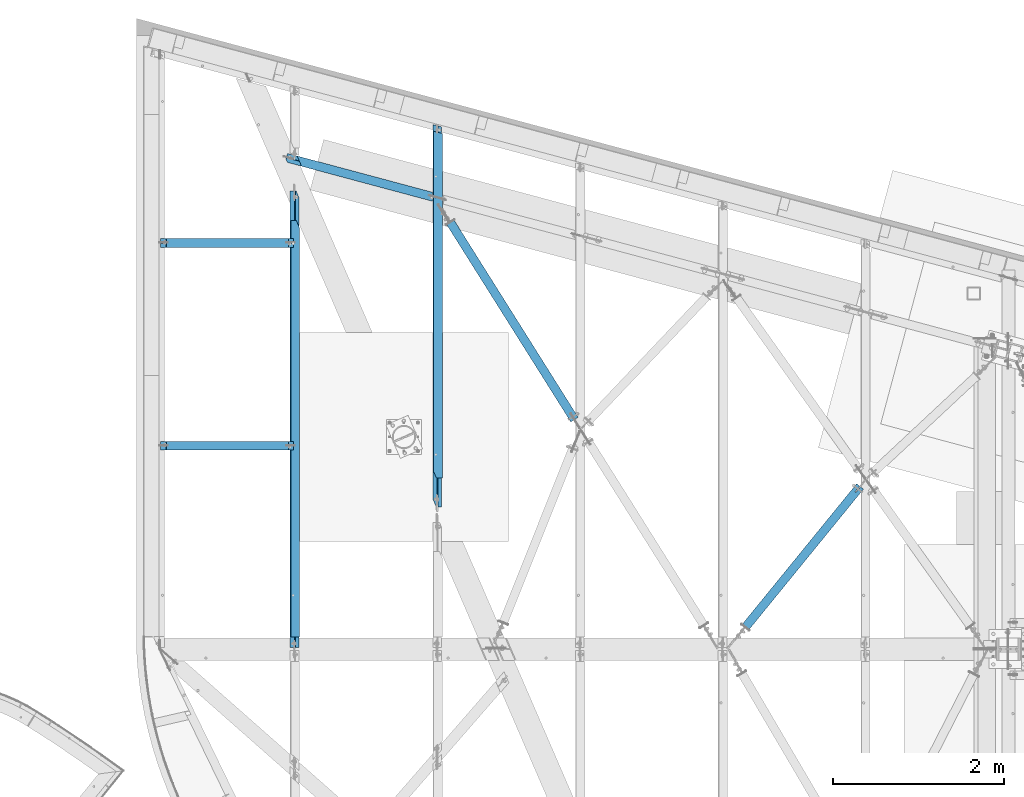
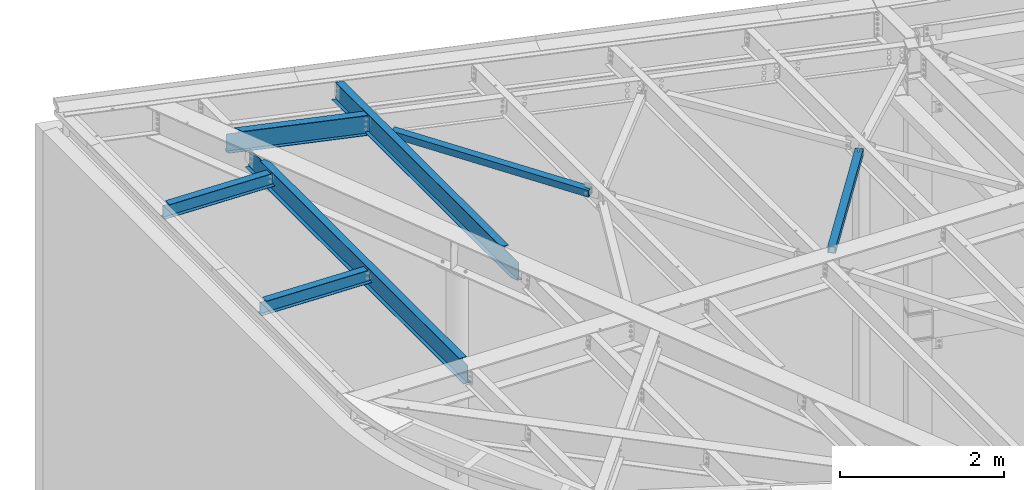
# One storey, part 1156 of 1763: 7 beams, 7 elements without a shape of their own.
"""IFC2X3 building model written with IfcOpenShell, lengths in millimetres."""

from ifc_helpers import new_model, si_unit, frame, origin_with_axes, place, context, subcontext, project, spatial, faceted_brep, material, type_object, element, aggregate, save


model = new_model("IFC2X3")

# Units and contexts
model_context = context("Model", 3, precision=1e-05, world=origin_with_axes())
body_context = subcontext(model_context, "Body", "Model", "MODEL_VIEW")
ifc_project = project(units=[si_unit("LENGTHUNIT", "METRE", prefix="MILLI"), si_unit("AREAUNIT", "SQUARE_METRE"), si_unit("VOLUMEUNIT", "CUBIC_METRE"), si_unit("MASSUNIT", "GRAM", prefix="KILO"), si_unit("TIMEUNIT", "SECOND"), si_unit("PLANEANGLEUNIT", "RADIAN"), si_unit("SOLIDANGLEUNIT", "STERADIAN"), si_unit("THERMODYNAMICTEMPERATUREUNIT", "DEGREE_CELSIUS"), si_unit("LUMINOUSINTENSITYUNIT", "LUMEN")], contexts=[model_context])

# Site, building, storey
site_placement = place(None, origin_with_axes())
site = spatial("IfcSite", under=ifc_project, at=site_placement, CompositionType="ELEMENT")
building_placement = place(site_placement, origin_with_axes())
building = spatial("IfcBuilding", under=site, at=building_placement, Name="Undefined", CompositionType="ELEMENT")
storey_placement = place(building_placement, origin_with_axes())
storey = spatial("IfcBuildingStorey", under=building, at=storey_placement, Name="Undefined", CompositionType="ELEMENT", Elevation=0.0)

# Assembly, beam
assembly_1_placement = place(storey_placement, origin_with_axes())
assembly_1 = element("IfcElementAssembly", 1, at=assembly_1_placement, inside=storey, Name="BEAM", AssemblyPlace="NOTDEFINED", PredefinedType="RIGID_FRAME")
ifc_material_1 = material(Name="STEEL/A992")
beam_type_1 = type_object("IfcBeamType", Name="W8X10", PredefinedType="NOTDEFINED")
beam_1_placement = place(assembly_1_placement, frame((-49594.0809324996, 67943.2756347656, 12638.1308830009), z_axis=(0.0294510340064007, 0.0, 0.999566224217262), x_axis=(0.999566224217262, 0.0, -0.0294510340064019)))
beam_1 = element("IfcBeam", 2, at=beam_1_placement, type_object=beam_type_1, material=ifc_material_1, Name="BEAM", ObjectType="W8X10", context=body_context, shape_type="Brep", body=[
    faceted_brep([(1510.54948678825, -50.8000000000029, 100.012500000068), (1510.54948678827, -50.8000000000029, 95.2500000000618), (1510.54948678827, -2.38125000000582, 95.2500000000618), (1510.54948678809, -2.38125000000582, 87.0525014935247), (1510.54948678809, 2.38125000000582, 87.0525014935247), (1510.54948678827, 2.38125000000582, 95.2500000000618), (1510.54948678827, 50.8000000000029, 95.2500000000618), (1510.54948678825, 50.8000000000029, 100.012500000068), (1511.51621671064, -2.38125000000582, 82.1924219754746), (1511.51621671064, 2.38125000000582, 82.1924219754746), (1514.26923061107, -2.38125000000582, 78.0722455073264), (1514.26923061107, 2.38125000000582, 78.0722455073264), (1518.38940707916, -2.38125000000582, 75.3192316068616), (1518.38940707916, 2.38125000000582, 75.3192316068616), (1523.24948659716, -2.38125000000582, 74.3525016842905), (1523.24948659716, 2.38125000000582, 74.3525016842905), (1574.04839155371, -2.38125000000582, 74.3525016841086), (1574.04839155371, 2.38125000000582, 74.3525016841086), (82.3286389559144, -50.8000000000029, 100.012500000101), (82.3286389559144, 50.8000000000029, 100.012500000101), (82.3286389559144, 50.8000000000029, 95.2500000000946), (82.3286389559144, 2.38125000000582, 95.2500000000946), (82.3286389557325, 2.38125000000582, 87.0525014876221), (82.3286389557325, -2.38125000000582, 87.0525014876221), (82.3286389559144, -2.38125000000582, 95.2500000000946), (82.3286389559144, -50.8000000000029, 95.2500000000946), (81.3619090331122, 2.38125000000582, 82.1924219695575), (81.3619090331122, -2.38125000000582, 82.1924219695575), (78.608895132631, 2.38125000000582, 78.0722455013802), (78.608895132631, -2.38125000000582, 78.0722455013802), (74.4887186644919, 2.38125000000582, 75.319231600879), (74.4887186644919, -2.38125000000582, 75.319231600879), (69.6286391464819, 2.38125000000582, 74.3525016782714), (69.6286391464819, -2.38125000000582, 74.3525016782714), (16.637930625453, 2.38125000000582, 74.3525016784588), (16.637930625453, -2.38125000000582, 74.3525016784588), (21.6350673062043, 2.38125000000582, -95.2500000000909), (21.6350673062043, 50.8000000000029, -95.2500000000909), (21.7753887236686, 50.8000000000029, -100.012500000097), (21.7753887236686, -50.8000000000029, -100.012500000097), (21.6350673062043, -50.8000000000029, -95.2500000000909), (21.6350673062043, -2.38125000000582, -95.2500000000909), (1574.05088986492, 2.38125000000582, -95.2500000001255), (1574.05088986492, 50.8000000000029, -95.2500000001255), (1574.0509600184, 50.8000000000029, -100.01250000013), (1574.0509600184, -50.8000000000029, -100.01250000013), (1574.05088986492, -50.8000000000029, -95.2500000001255), (1574.05088986492, -2.38125000000582, -95.2500000001255)], [[[0, 1, 2, 3, 4, 5, 6, 7]], [[8, 9, 4, 3]], [[10, 11, 9, 8]], [[12, 13, 11, 10]], [[14, 15, 13, 12]], [[16, 17, 15, 14]], [[18, 19, 20, 21, 22, 23, 24, 25]], [[23, 22, 26, 27]], [[27, 26, 28, 29]], [[29, 28, 30, 31]], [[31, 30, 32, 33]], [[33, 32, 34, 35]], [[36, 37, 38, 39, 40, 41, 35, 34]], [[37, 36, 42, 43]], [[38, 37, 43, 44]], [[39, 38, 44, 45]], [[40, 39, 45, 46]], [[41, 40, 46, 47]], [[12, 10, 8, 3, 2, 24, 23, 27, 29, 31, 33, 35, 41, 47, 16, 14]], [[25, 24, 2, 1]], [[18, 25, 1, 0]], [[19, 18, 0, 7]], [[20, 19, 7, 6]], [[21, 20, 6, 5]], [[42, 36, 34, 32, 30, 28, 26, 22, 21, 5, 4, 9, 11, 13, 15, 17]], [[47, 46, 45, 44, 43, 42, 17, 16]]]),
])
aggregate(assembly_1, [beam_1])

assembly_2_placement = place(storey_placement, origin_with_axes())
assembly_2 = element("IfcElementAssembly", 3, at=assembly_2_placement, inside=storey, Name="BEAM", AssemblyPlace="NOTDEFINED", PredefinedType="RIGID_FRAME")
beam_2_placement = place(assembly_2_placement, frame((-49594.0809324532, 65574.7256347656, 12638.1308829993), z_axis=(0.0294510340064007, 0.0, 0.999566224217262), x_axis=(0.999566224217262, 0.0, -0.0294510340064019)))
beam_2 = element("IfcBeam", 4, at=beam_2_placement, type_object=beam_type_1, material=ifc_material_1, Name="BEAM", ObjectType="W8X10", context=body_context, shape_type="Brep", body=[
    faceted_brep([(1510.54948678825, -50.8000000000029, 100.012500000068), (1510.54948678827, -50.8000000000029, 95.2500000000618), (1510.54948678827, -2.38125000000582, 95.2500000000618), (1510.54948678809, -2.38125000000582, 87.0525014935247), (1510.54948678809, 2.38125000000582, 87.0525014935247), (1510.54948678827, 2.38125000000582, 95.2500000000618), (1510.54948678827, 50.8000000000029, 95.2500000000618), (1510.54948678825, 50.8000000000029, 100.012500000068), (1511.51621671064, -2.38125000000582, 82.1924219754746), (1511.51621671064, 2.38125000000582, 82.1924219754746), (1514.26923061107, -2.38125000000582, 78.0722455073264), (1514.26923061107, 2.38125000000582, 78.0722455073264), (1518.38940707916, -2.38125000000582, 75.3192316068616), (1518.38940707916, 2.38125000000582, 75.3192316068616), (1523.24948659716, -2.38125000000582, 74.3525016842905), (1523.24948659716, 2.38125000000582, 74.3525016842905), (1574.04839155371, -2.38125000000582, 74.3525016841086), (1574.04839155371, 2.38125000000582, 74.3525016841086), (82.3286389559144, -50.8000000000029, 100.012500000101), (82.3286389559144, 50.8000000000029, 100.012500000101), (82.3286389559144, 50.8000000000029, 95.2500000000946), (82.3286389559144, 2.38125000000582, 95.2500000000946), (82.3286389557325, 2.38125000000582, 87.0525014876221), (82.3286389557325, -2.38125000000582, 87.0525014876221), (82.3286389559144, -2.38125000000582, 95.2500000000946), (82.3286389559144, -50.8000000000029, 95.2500000000946), (81.3619090331122, 2.38125000000582, 82.1924219695575), (81.3619090331122, -2.38125000000582, 82.1924219695575), (78.608895132631, 2.38125000000582, 78.0722455013802), (78.608895132631, -2.38125000000582, 78.0722455013802), (74.4887186644919, 2.38125000000582, 75.319231600879), (74.4887186644919, -2.38125000000582, 75.319231600879), (69.6286391464819, 2.38125000000582, 74.3525016782714), (69.6286391464819, -2.38125000000582, 74.3525016782714), (16.637930625453, 2.38125000000582, 74.3525016784588), (16.637930625453, -2.38125000000582, 74.3525016784588), (21.6350673062043, 2.38125000000582, -95.2500000000909), (21.6350673062043, 50.8000000000029, -95.2500000000909), (21.7753887236686, 50.8000000000029, -100.012500000097), (21.7753887236686, -50.8000000000029, -100.012500000097), (21.6350673062043, -50.8000000000029, -95.2500000000909), (21.6350673062043, -2.38125000000582, -95.2500000000909), (1574.05088986492, 2.38125000000582, -95.2500000001255), (1574.05088986492, 50.8000000000029, -95.2500000001255), (1574.0509600184, 50.8000000000029, -100.01250000013), (1574.0509600184, -50.8000000000029, -100.01250000013), (1574.05088986492, -50.8000000000029, -95.2500000001255), (1574.05088986492, -2.38125000000582, -95.2500000001255)], [[[0, 1, 2, 3, 4, 5, 6, 7]], [[8, 9, 4, 3]], [[10, 11, 9, 8]], [[12, 13, 11, 10]], [[14, 15, 13, 12]], [[16, 17, 15, 14]], [[18, 19, 20, 21, 22, 23, 24, 25]], [[23, 22, 26, 27]], [[27, 26, 28, 29]], [[29, 28, 30, 31]], [[31, 30, 32, 33]], [[33, 32, 34, 35]], [[36, 37, 38, 39, 40, 41, 35, 34]], [[37, 36, 42, 43]], [[38, 37, 43, 44]], [[39, 38, 44, 45]], [[40, 39, 45, 46]], [[41, 40, 46, 47]], [[12, 10, 8, 3, 2, 24, 23, 27, 29, 31, 33, 35, 41, 47, 16, 14]], [[25, 24, 2, 1]], [[18, 25, 1, 0]], [[19, 18, 0, 7]], [[20, 19, 7, 6]], [[21, 20, 6, 5]], [[42, 36, 34, 32, 30, 28, 26, 22, 21, 5, 4, 9, 11, 13, 15, 17]], [[47, 46, 45, 44, 43, 42, 17, 16]]]),
])
aggregate(assembly_2, [beam_2])

assembly_3_placement = place(storey_placement, origin_with_axes())
assembly_3 = element("IfcElementAssembly", 5, at=assembly_3_placement, inside=storey, Name="H. BRACE", AssemblyPlace="NOTDEFINED", PredefinedType="RIGID_FRAME")
ifc_material_2 = material()
beam_type_2 = type_object("IfcBeamType", Name="HSS4X4X3/8", PredefinedType="NOTDEFINED")
beam_3_placement = place(assembly_3_placement, frame((-44670.2201695923, 65768.4829644201, 12475.765625), z_axis=(0.0, 0.0, 1.0), x_axis=(-0.532535588045035, 0.84640761307158, 0.0)))
beam_3 = element("IfcBeam", 6, at=beam_3_placement, type_object=beam_type_2, material=ifc_material_2, Name="H. BRACE", ObjectType="HSS4X4X3/8", context=body_context, shape_type="Brep", body=[
    faceted_brep([(134.399493874473, 6.34999914010314, 50.7999999999993), (134.399493874473, 6.34999914010314, 41.2749999999996), (218.319021807634, 6.34999913892443, 41.2749999999996), (218.319021807634, 6.34999913892443, 50.7999999999993), (218.319021807751, -6.35000086107993, 50.7999999999993), (218.319021807751, -6.35000086107993, 41.2749999999996), (134.399493874531, -6.35000086142918, 41.2749999999996), (134.399493874531, -6.35000086142918, 50.7999999999993), (134.399493874473, 6.34999914010314, -41.2749999999996), (134.399493874473, 6.34999914010314, -50.7999999999993), (218.319021807634, 6.34999913892443, -50.7999999999993), (218.319021807634, 6.34999913892443, -41.2749999999996), (218.319021807751, -6.35000086107993, -41.2749999999996), (218.319021807751, -6.35000086107993, -50.7999999999993), (134.399493874531, -6.35000086142918, -50.7999999999993), (134.399493874531, -6.35000086142918, -41.2749999999996), (134.399493874662, -41.274999999966, -41.2749999999996), (134.399493874662, -41.274999999966, 41.2749999999996), (2854.66123110603, -41.2749999991511, 41.2749999999996), (2854.66123110603, -41.2749999991511, -41.2749999999996), (134.399493874313, 50.8000000000457, -50.7999999999993), (2854.6612311057, 50.8000000008606, -50.7999999999993), (2854.66123110607, -50.7999999991598, -50.7999999999993), (134.399493874691, -50.7999999999602, -50.7999999999993), (134.399493874691, -50.7999999999602, 50.7999999999993), (2854.66123110607, -50.7999999991598, 50.7999999999993), (134.399493874342, 41.2750000000515, 41.2749999999996), (2854.66123110571, 41.2750000008591, 41.2749999999996), (134.399493874342, 41.2750000000515, -41.2749999999996), (2854.66123110571, 41.2750000008591, -41.2749999999996), (2854.6612311057, 50.8000000008606, 50.7999999999993), (134.399493874313, 50.8000000000457, 50.7999999999993)], [[[0, 1, 2, 3]], [[4, 5, 6, 7]], [[3, 2, 5, 4]], [[8, 9, 10, 11]], [[12, 13, 14, 15]], [[11, 10, 13, 12]], [[16, 17, 18, 19]], [[9, 20, 21, 22, 23, 14, 13, 10]], [[24, 23, 22, 25]], [[17, 16, 15, 14, 23, 24, 7, 6]], [[1, 26, 27, 18, 17, 6, 5, 2]], [[26, 28, 29, 27]], [[25, 22, 21, 30], [18, 27, 29, 19]], [[20, 31, 30, 21]], [[24, 25, 30, 31, 0, 3, 4, 7]], [[31, 20, 9, 8, 28, 26, 1, 0]], [[16, 19, 29, 28, 8, 11, 12, 15]]]),
])
aggregate(assembly_3, [beam_3])

assembly_4_placement = place(storey_placement, origin_with_axes())
assembly_4 = element("IfcElementAssembly", 7, at=assembly_4_placement, inside=storey, Name="H. BRACE", AssemblyPlace="NOTDEFINED", PredefinedType="RIGID_FRAME")
beam_4_placement = place(assembly_4_placement, frame((-41338.5382217806, 65184.4596804294, 12382.5), z_axis=(0.0, 0.0, 1.0), x_axis=(-0.631517084157289, -0.775361962194094, 1.58124748850241e-11)))
beam_4 = element("IfcBeam", 8, at=beam_4_placement, type_object=beam_type_2, material=ifc_material_2, Name="H. BRACE", ObjectType="HSS4X4X3/8", context=body_context, shape_type="Brep", body=[
    faceted_brep([(107.619238474028, 6.34999999280262, 50.7999999999993), (107.619238474028, 6.34999999280262, 41.2749999999996), (191.849362311121, 6.34999999300635, 41.2749999999996), (191.849362311121, 6.34999999300635, 50.7999999999993), (191.84936231115, -6.35000000697619, 50.7999999999993), (191.84936231115, -6.35000000697619, 41.2749999999996), (107.619238474028, -6.35000000716536, 41.2749999999996), (107.619238474028, -6.35000000716536, 50.7999999999993), (107.619238474028, 6.34999999280262, -41.2749999999996), (107.619238474028, 6.34999999280262, -50.7999999999993), (191.849362311121, 6.34999999300635, -50.7999999999993), (191.849362311121, 6.34999999300635, -41.2749999999996), (191.84936231115, -6.35000000697619, -41.2749999999996), (191.84936231115, -6.35000000697619, -50.7999999999993), (107.619238474028, -6.35000000716536, -50.7999999999993), (107.619238474028, -6.35000000716536, -41.2749999999996), (107.619238474032, -41.2749999997322, -41.2749999999996), (107.619238474032, -41.2749999997322, 41.2749999999996), (2223.9086201407, -41.27499999477, 41.2749999999996), (2223.90862018824, -41.27499999477, -41.2749999999996), (107.619238474032, 50.8000000001921, -50.7999999999993), (2223.90862020535, 50.8000000051252, -50.7999999999993), (2223.90862019252, -50.7999999947642, -50.7999999999993), (107.619238474028, -50.7999999997119, -50.7999999999993), (107.619238474028, -50.7999999997119, 50.7999999999993), (2223.908620134, -50.7999999947642, 50.7999999999993), (107.619238474028, 41.2750000001979, 41.2749999999996), (2223.90862015112, 41.2750000051456, 41.2749999999996), (107.619238474028, 41.2750000001979, -41.2749999999996), (2223.90862019866, 41.2750000051601, -41.2749999999996), (2223.90862014683, 50.8000000051252, 50.7999999999993), (107.619238474032, 50.8000000001921, 50.7999999999993)], [[[0, 1, 2, 3]], [[4, 5, 6, 7]], [[3, 2, 5, 4]], [[8, 9, 10, 11]], [[12, 13, 14, 15]], [[11, 10, 13, 12]], [[16, 17, 18, 19]], [[9, 20, 21, 22, 23, 14, 13, 10]], [[24, 23, 22, 25]], [[17, 16, 15, 14, 23, 24, 7, 6]], [[1, 26, 27, 18, 17, 6, 5, 2]], [[26, 28, 29, 27]], [[25, 22, 21, 30], [18, 27, 29, 19]], [[20, 31, 30, 21]], [[24, 25, 30, 31, 0, 3, 4, 7]], [[31, 20, 9, 8, 28, 26, 1, 0]], [[16, 19, 29, 28, 8, 11, 12, 15]]]),
])
aggregate(assembly_4, [beam_4])

assembly_5_placement = place(storey_placement, origin_with_axes())
assembly_5 = element("IfcElementAssembly", 9, at=assembly_5_placement, inside=storey, Name="BEAM", AssemblyPlace="NOTDEFINED", PredefinedType="RIGID_FRAME")
beam_type_3 = type_object("IfcBeamType", Name="W12X16", PredefinedType="NOTDEFINED")
beam_5_placement = place(assembly_5_placement, frame((-46340.5472371748, 64763.7724039031, 12489.8609543427), z_axis=(0.0294363099980619, 0.0, 0.999566657934176), x_axis=(0.0, 1.0, 0.0)))
beam_5 = element("IfcBeam", 10, at=beam_5_placement, type_object=beam_type_3, material=ifc_material_1, Name="BEAM", ObjectType="W12X16", context=body_context, shape_type="Brep", body=[
    faceted_brep([(426.121912281051, -3.17499999984284, 104.52697750146), (426.121912281051, 3.17500000015571, 104.339975897325), (98.8917058526349, 3.17500000015571, 104.339975897237), (98.8917058526349, -3.17499999983556, 104.526977501373), (430.981991799097, -3.17499999983556, 105.494126530408), (430.981991799097, 3.17500000015571, 105.30712492627), (435.102168267251, -3.17499999982829, 108.248333944819), (435.102168267251, 3.17500000016298, 108.06133234068), (437.855182167732, -3.17499999982101, 112.3702966328), (437.855182167732, 3.17500000017026, 112.183295028663), (438.821912090316, -3.17499999982101, 117.23248314079), (438.821912090316, 3.17500000017753, 117.045481536654), (438.821912090316, -50.7999999997774, 152.400000000001), (438.821912090316, 19.0582626730247, 152.400000000021), (438.821912090316, 18.8712617906058, 146.050000000021), (438.821912090316, 3.17500000022847, 146.050000000016), (438.821912090316, -3.17499999977736, 146.050000000014), (438.821912090316, -50.7999999997846, 146.050000000001), (4486.04136611942, 50.8000000002503, 152.400000000031), (4486.09145163643, 50.8000000002357, 146.050000000028), (512.615117098285, 50.8000000002357, 146.050000000028), (512.18292355648, 50.8000000002503, 152.400000000031), (192.99809656541, 50.7999999997774, -152.400000000005), (192.565901363618, 50.7999999997846, -146.050000000005), (4563.17466166045, 50.7999999997846, -146.050000000005), (4563.22474687551, 50.7999999997774, -152.400000000005), (4535.96282073851, -50.8000000002357, -146.050000000032), (4548.71837117067, -3.17500000022847, -146.050000000019), (98.8917058526349, -3.17500000022847, -146.050000000019), (98.8917058526349, -50.8000000002357, -146.050000000032), (4536.01290595357, -50.800000000243, -152.400000000034), (98.8917058526349, -50.800000000243, -152.400000000034), (98.8917058363513, 10.0821817836841, -152.400000000018), (98.8917058377701, 10.2691833845674, -146.050000000016), (4550.4191112283, 3.17499999977736, -146.050000000017), (98.8917058526349, 3.17499999977736, -146.050000000017), (4548.3173604348, 3.17500000019209, 120.418208737223), (4546.61662037717, -3.17499999981374, 120.418208737212), (4486.58590783367, 3.17500000018481, 120.418208726283), (4484.88516778157, -3.17499999982101, 120.418208726271), (4481.57767445687, 3.17500000019209, 121.375702947129), (4479.87693440478, -3.17499999981374, 121.375702947118), (4477.32461503113, 3.17500000019209, 124.103808415017), (4475.62387497904, -3.17499999981374, 124.103808415004), (4474.46803347551, 3.17500000019936, 128.191163671509), (4472.76729342343, -3.17499999979918, 128.191163671496), (4473.43866370727, 3.17500000020664, 133.02145074824), (4471.73792365518, -3.17499999979191, 133.021450748223), (4458.82952528688, -50.7999999997774, 152.400000000001), (4458.8796108039, -50.7999999997846, 146.050000000001), (4471.63516119415, -3.17499999977736, 146.050000000014), (4473.33590124617, 3.17500000022847, 146.050000000016)], [[[0, 1, 2, 3]], [[4, 5, 1, 0]], [[6, 7, 5, 4]], [[8, 9, 7, 6]], [[10, 11, 9, 8]], [[12, 13, 14, 15, 11, 10, 16, 17]], [[18, 19, 20, 21]], [[22, 23, 24, 25]], [[26, 27, 28, 29]], [[30, 26, 29, 31]], [[22, 25, 30, 31, 32]], [[23, 22, 32, 33]], [[34, 24, 23, 33, 35]], [[27, 26, 30, 25, 24, 34, 36, 37]], [[36, 38, 39, 37]], [[40, 41, 39, 38]], [[42, 43, 41, 40]], [[44, 45, 43, 42]], [[46, 47, 45, 44]], [[18, 48, 49, 50, 47, 46, 51, 19]], [[49, 48, 12, 17]], [[50, 49, 17, 16]], [[8, 6, 4, 0, 3, 28, 27, 37, 39, 41, 43, 45, 47, 50, 16, 10]], [[35, 33, 32, 31, 29, 28, 3, 2]], [[51, 46, 44, 42, 40, 38, 36, 34, 35, 2, 1, 5, 7, 9, 11, 15]], [[20, 19, 51, 15, 14]], [[21, 20, 14, 13]], [[48, 18, 21, 13, 12]]]),
])
aggregate(assembly_5, [beam_5])

assembly_6_placement = place(storey_placement, origin_with_axes())
assembly_6 = element("IfcElementAssembly", 11, at=assembly_6_placement, inside=storey, Name="BEAM", AssemblyPlace="NOTDEFINED", PredefinedType="RIGID_FRAME")
beam_6_placement = place(assembly_6_placement, frame((-48006.388211116, 63201.55, 12538.9411647992), z_axis=(0.0294363099980619, 0.0, 0.999566657934176), x_axis=(0.0, 1.0, 0.0)))
beam_6 = element("IfcBeam", 12, at=beam_6_placement, type_object=beam_type_3, material=ifc_material_1, Name="BEAM", ObjectType="W12X16", context=body_context, shape_type="Brep", body=[
    faceted_brep([(5344.04394126798, -3.17499999982829, 113.600144179083), (5344.04108899167, 3.17500000017026, 113.600144179074), (5343.46250938192, 3.17500000017026, 113.600144179074), (5343.46222122431, -3.17499999982829, 113.600144179083), (18.2562499854539, -50.8000000002503, -146.050000000032), (18.2562499854539, -50.8000000002576, -152.400000000032), (5276.15883169106, -50.8000000002576, -152.400000000032), (5275.72663648927, -50.800000000243, -146.050000000034), (5343.45686645915, -3.17499999983556, 111.597654384646), (5343.45686645915, 3.17500000016298, 111.410652780509), (5016.22665996959, 3.17500000016298, 111.410652780509), (5016.22665996959, -3.17499999983556, 111.597654384646), (5011.36658045155, 3.17500000016298, 112.377801809454), (5011.36658045155, -3.17499999982829, 112.564803413592), (5007.24640398339, 3.17500000017026, 115.132009223866), (5007.24640398339, -3.17499999982829, 115.319010828001), (5004.49339008291, 3.17500000017753, 119.253971911845), (5004.49339008291, -3.17499999982829, 119.440973515984), (5003.52666016032, 3.17500000018481, 124.116158419838), (5003.52666016032, -3.17499999981374, 124.303160023974), (142.874993882375, 3.17500000022119, 146.050000000019), (142.874993882375, 50.8000000002212, 146.05000000003), (5003.52666016032, 50.8000000002285, 146.05000000003), (5003.52666016032, 3.17500000022119, 146.050000000017), (5003.52666016032, -3.17499999978463, 146.050000000014), (5003.52666016032, 50.8000000002357, 152.400000000029), (5003.52666016032, -12.7055041987333, 152.400000000014), (5003.52666016032, -12.8925076171872, 146.050000000012), (142.874993882375, 50.8000000002285, 152.400000000032), (142.874993882375, -50.7999999997919, 152.400000000001), (4915.48325174667, -50.7999999997846, 152.400000000001), (142.874993882375, -50.7999999997992, 146.050000000001), (4915.91545114973, -50.7999999997919, 146.050000000001), (142.874993882375, -3.17499999979191, 146.050000000014), (142.874993895377, 3.17500000017753, 120.673538648722), (142.874993895377, -3.17499999982101, 120.673538648709), (141.908263972786, 3.17500000017026, 115.813459130675), (141.908263972786, -3.17499999982829, 115.813459130661), (139.155250072312, 3.17500000017026, 111.693282662518), (139.155250072312, -3.17499999984284, 111.693282662505), (135.035073604158, 3.17500000016298, 108.94026876204), (135.035073604158, -3.17499999984284, 108.940268762026), (130.174994086112, 3.17500000016298, 107.973538839451), (130.174994086112, -3.17499999984284, 107.973538839438), (18.2562499988926, 3.17500000016298, 107.97353883966), (18.2562499988926, -3.17499999984284, 107.973538839671), (18.2562499854539, 3.17499999977008, -146.050000000016), (18.2562499854539, 50.7999999997701, -146.050000000005), (18.2562499854539, 50.7999999997628, -152.400000000003), (18.2562499854539, -3.17500000024302, -146.050000000019), (5348.00145052215, 3.17499999977008, -146.050000000019), (5347.98005844971, 50.7999999997774, -146.050000000005), (5348.07691299143, 50.7999999997701, -152.400000000003), (5348.10856602334, -19.668892106929, -152.400000000023), (5348.01164632103, -19.5238255845106, -146.050000000027), (5348.00430279848, -3.17500000023574, -146.050000000021)], [[[0, 1, 2, 3]], [[4, 5, 6, 7]], [[8, 9, 10, 11]], [[11, 10, 12, 13]], [[13, 12, 14, 15]], [[15, 14, 16, 17]], [[17, 16, 18, 19]], [[20, 21, 22, 23]], [[24, 19, 18, 23, 22, 25, 26, 27]], [[21, 28, 25, 22]], [[25, 28, 29, 30, 26]], [[29, 31, 32, 30]], [[26, 30, 32, 27]], [[31, 33, 24, 27, 32]], [[29, 28, 21, 20, 34, 35, 33, 31]], [[35, 34, 36, 37]], [[37, 36, 38, 39]], [[39, 38, 40, 41]], [[41, 40, 42, 43]], [[43, 42, 44, 45]], [[46, 47, 48, 5, 4, 49, 45, 44]], [[47, 46, 50, 51]], [[48, 47, 51, 52]], [[6, 5, 48, 52, 53]], [[7, 6, 53, 54]], [[49, 4, 7, 54, 55]], [[8, 11, 13, 15, 17, 19, 24, 33, 35, 37, 39, 41, 43, 45, 49, 55, 0, 3]], [[9, 8, 3, 2]], [[50, 46, 44, 42, 40, 38, 36, 34, 20, 23, 18, 16, 14, 12, 10, 9, 2, 1]], [[55, 54, 53, 52, 51, 50, 1, 0]]]),
])
aggregate(assembly_6, [beam_6])

assembly_7_placement = place(storey_placement, origin_with_axes())
assembly_7 = element("IfcElementAssembly", 13, at=assembly_7_placement, inside=storey, Name="BEAM", AssemblyPlace="NOTDEFINED", PredefinedType="RIGID_FRAME")
beam_type_4 = type_object("IfcBeamType", Name="W12X14", PredefinedType="NOTDEFINED")
beam_7_placement = place(assembly_7_placement, frame((-48148.5189487661, 68952.6013740349, 12553.5440318149), z_axis=(0.0284332150015107, -0.00761865702657088, 0.99956666028324), x_axis=(0.965507252136511, -0.258706889036504, -0.029436230004148)))
beam_7 = element("IfcBeam", 14, at=beam_7_placement, type_object=beam_type_4, material=ifc_material_1, Name="BEAM", ObjectType="W12X14", context=body_context, shape_type="Brep", body=[
    faceted_brep([(1820.84643826731, -50.7999999975873, 150.81250000139), (1820.83984694576, -50.7999999975946, 144.462500001391), (1807.87210041872, -2.38124999755382, 144.462500001371), (1807.84666766232, -2.38124999757565, 119.960887754036), (1806.57115161051, 2.38125000242871, 119.960887754363), (1806.59658436687, 2.38125000245054, 144.462500001369), (1793.62883783983, 50.8000000024767, 144.462500001349), (1793.63542916137, 50.8000000024767, 150.812500001348), (1808.84368227317, -2.38124999757565, 115.096899169623), (1807.56816622136, 2.38125000242871, 115.096899169952), (1811.69284399089, -2.38124999756837, 110.972401145638), (1810.41732793908, 2.38125000242144, 110.972401145966), (1815.9598469898, -2.38124999756837, 108.216102648899), (1814.68433093796, 2.38125000242871, 108.216102649229), (1820.99425986432, -2.38124999756837, 107.248154100151), (1819.71874381251, 2.38125000243599, 107.24815410048), (1855.86147616999, -2.38124999752472, 107.248154105149), (1855.86147620413, 2.38125000247237, 107.24815410567), (236.805937729907, -50.7999999996246, 150.81250000016), (156.278366708008, 50.8000000003667, 150.81250000008), (156.465369243524, 50.800000000374, 144.462500000081), (194.841789808648, 2.38125000037689, 144.462500000118), (195.479646132328, 2.38125000034779, 122.80296654887), (199.25437602395, -2.38124999964202, 122.802966547897), (198.616519700299, -2.38124999962747, 144.462500000123), (236.992940265416, -50.7999999996391, 144.462500000163), (194.355479406069, 2.38125000035507, 117.853637030268), (198.130209297706, -2.38124999964202, 117.853637029299), (190.868965737471, 2.38125000034779, 113.633889019111), (194.6436956291, -2.3812499996493, 113.633889018141), (185.56639603823, 2.38125000031869, 110.804901620751), (189.341125929852, -2.38124999967113, 110.804901619782), (179.278613354087, 2.38125000031869, 109.809940014096), (183.053343245709, -2.38124999968568, 109.809940013125), (40.6218642095628, 2.38125000014406, 109.8099399886), (40.6216492422245, -2.38124999986758, 109.809939986926), (73.2738299476259, -50.8000000000466, -144.4624999999), (73.460831035547, -50.8000000000393, -150.8124999999), (1820.53335119649, -50.7999999978056, -150.812499998545), (1820.53994270782, -50.799999997791, -144.462499998546), (48.1097158917546, -2.38125000003492, -144.462499999929), (48.1089635058088, -19.0499999428939, -144.462500008434), (1807.57219618076, -2.38124999776483, -144.462499998564), (48.2959648839169, -19.0499997154184, -150.812499999924), (48.2991174501367, 50.8000000000175, -150.812499999935), (48.1121163609641, 50.800000000032, -144.462499999938), (1793.32893360186, 50.800000002273, -144.462499998586), (1793.32234209056, 50.800000002273, -150.812499998583), (48.1099308591438, 2.38124999997672, -144.462499999931), (1806.29668012892, 2.38125000225409, -144.462499998566), (1806.30427648451, 2.38125000226137, -137.144472801678), (1807.57979253633, -2.38124999775755, -137.144472802005), (1807.30885836906, 2.38125000225409, -132.288305211057), (1808.58437442088, -2.38124999775027, -132.288305211385), (1810.15977447828, 2.38125000226137, -128.172449931804), (1811.4352905301, -2.381249997743, -128.172449932132), (1814.42354548147, 2.38125000226864, -125.42271920229), (1815.69906153329, -2.381249997743, -125.422719202617), (1819.45186868226, 2.38125000226864, -124.457207203672), (1820.72738473408, -2.38124999772117, -124.457207204003), (1855.62096614038, 2.3812500023123, -124.457207199475), (1855.62096595261, -2.38124999769207, -124.457207199981)], [[[0, 1, 2, 3, 4, 5, 6, 7]], [[8, 9, 4, 3]], [[10, 11, 9, 8]], [[12, 13, 11, 10]], [[14, 15, 13, 12]], [[16, 17, 15, 14]], [[18, 19, 20, 21, 22, 23, 24, 25]], [[23, 22, 26, 27]], [[27, 26, 28, 29]], [[29, 28, 30, 31]], [[31, 30, 32, 33]], [[33, 32, 34, 35]], [[36, 37, 38, 39]], [[40, 41, 36, 39, 42]], [[37, 36, 41, 43]], [[44, 45, 46, 47]], [[37, 43, 44, 47, 38]], [[41, 40, 35, 34, 48, 45, 44, 43]], [[45, 48, 49, 46]], [[39, 38, 47, 46, 49, 50, 51, 42]], [[51, 50, 52, 53]], [[53, 52, 54, 55]], [[55, 54, 56, 57]], [[57, 56, 58, 59]], [[59, 58, 60, 61]], [[12, 10, 8, 3, 2, 24, 23, 27, 29, 31, 33, 35, 40, 42, 51, 53, 55, 57, 59, 61, 16, 14]], [[25, 24, 2, 1]], [[18, 25, 1, 0]], [[19, 18, 0, 7]], [[20, 19, 7, 6]], [[21, 20, 6, 5]], [[60, 58, 56, 54, 52, 50, 49, 48, 34, 32, 30, 28, 26, 22, 21, 5, 4, 9, 11, 13, 15, 17]], [[61, 60, 17, 16]]]),
])
aggregate(assembly_7, [beam_7])

save(model, "model.ifc")
